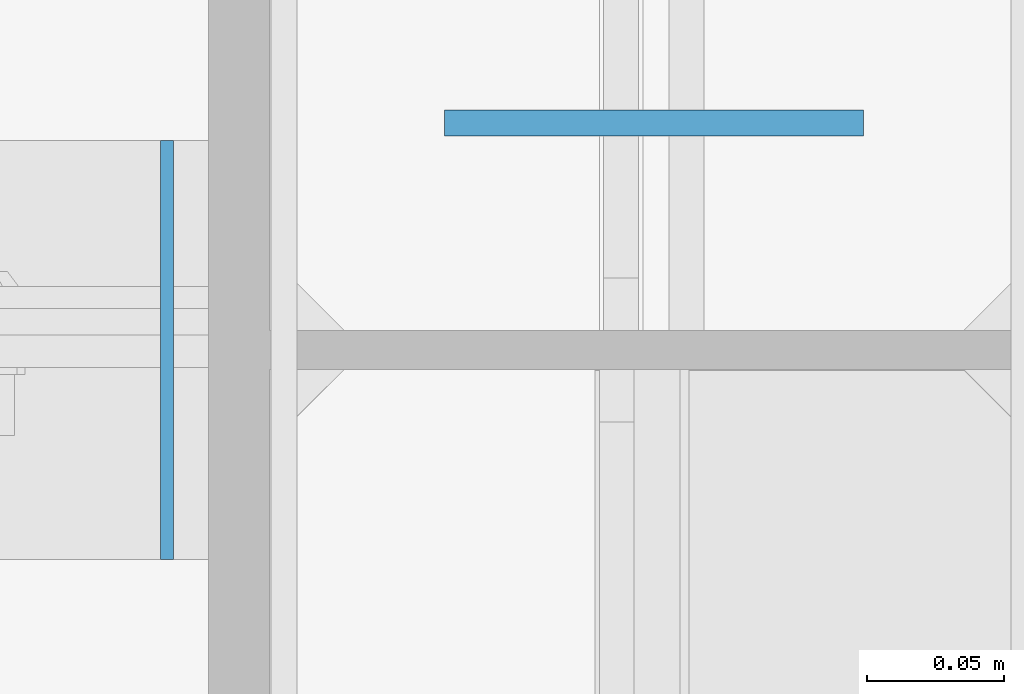
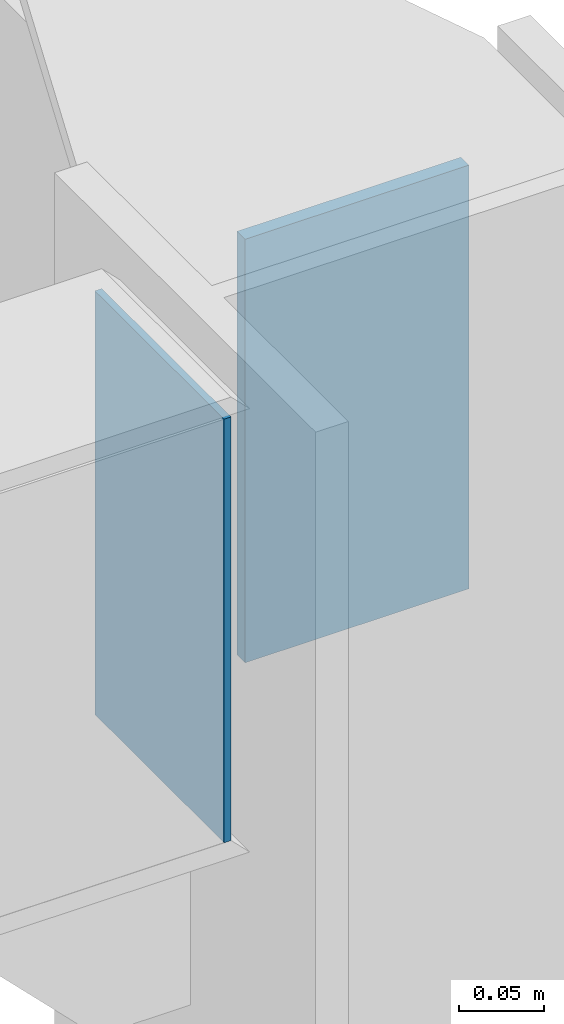
# One storey, part 556 of 1179: 2 columns, 2 elements without a shape of their own.
"""IFC2X3 building model written with IfcOpenShell, lengths in millimetres."""

from ifc_helpers import new_model, si_unit, frame, origin_with_axes, place, context, subcontext, project, spatial, faceted_brep, material, type_object, element, aggregate, save


model = new_model("IFC2X3")

# Units and contexts
model_context = context("Model", 3, precision=1e-05, world=origin_with_axes())
body_context = subcontext(model_context, "Body", "Model", "MODEL_VIEW")
ifc_project = project(units=[si_unit("LENGTHUNIT", "METRE", prefix="MILLI"), si_unit("AREAUNIT", "SQUARE_METRE"), si_unit("VOLUMEUNIT", "CUBIC_METRE"), si_unit("MASSUNIT", "GRAM", prefix="KILO"), si_unit("TIMEUNIT", "SECOND"), si_unit("PLANEANGLEUNIT", "RADIAN"), si_unit("SOLIDANGLEUNIT", "STERADIAN"), si_unit("THERMODYNAMICTEMPERATUREUNIT", "DEGREE_CELSIUS"), si_unit("LUMINOUSINTENSITYUNIT", "LUMEN")], contexts=[model_context])

# Site, building, storey
site_placement = place(None, origin_with_axes())
site = spatial("IfcSite", under=ifc_project, at=site_placement, CompositionType="ELEMENT")
building_placement = place(site_placement, origin_with_axes())
building = spatial("IfcBuilding", under=site, at=building_placement, Name="Undefined", CompositionType="ELEMENT")
storey_placement = place(building_placement, origin_with_axes())
storey = spatial("IfcBuildingStorey", under=building, at=storey_placement, Name="Undefined", CompositionType="ELEMENT", Elevation=0.0)

# Assembly, column
assembly_1_placement = place(storey_placement, origin_with_axes())
assembly_1 = element("IfcElementAssembly", 1, at=assembly_1_placement, inside=storey, Name="BEAM", AssemblyPlace="NOTDEFINED", PredefinedType="RIGID_FRAME")
ifc_material = material(Name="STEEL/A36")
column_type_1 = type_object("IfcColumnType", PredefinedType="NOTDEFINED")
column_1_placement = place(assembly_1_placement, frame((24307.8, 34474.15, 16122.65), z_axis=(1.0, 0.0, 0.0), x_axis=(0.0, 0.0, 1.0)))
column_1 = element("IfcColumn", 2, at=column_1_placement, type_object=column_type_1, material=ifc_material, Name="PLATE", context=body_context, shape_type="Brep", body=[
    faceted_brep([(0.0, 4.76249999999982, -76.1999999999971), (0.0, 4.76249999999982, 76.1999999999971), (304.799999999999, 4.76250000000073, 76.1999999999971), (304.799999999999, 4.76250000000073, -76.1999999999971), (0.0, -4.76249999999982, 76.1999999999971), (304.799999999999, -4.76250000000073, 76.1999999999971), (0.0, -4.76249999999982, -76.1999999999971), (304.799999999999, -4.76250000000073, -76.1999999999971)], [[[0, 1, 2, 3]], [[1, 4, 5, 2]], [[4, 6, 7, 5]], [[6, 0, 3, 7]], [[5, 7, 3, 2]], [[6, 4, 1, 0]]]),
])
aggregate(assembly_1, [column_1])

assembly_2_placement = place(storey_placement, origin_with_axes())
assembly_2 = element("IfcElementAssembly", 3, at=assembly_2_placement, inside=storey, Name="BEAM", AssemblyPlace="NOTDEFINED", PredefinedType="RIGID_FRAME")
column_type_2 = type_object("IfcColumnType", PredefinedType="NOTDEFINED")
column_2_placement = place(assembly_2_placement, frame((24130.7940000572, 34391.6, 16122.65), z_axis=(0.0, 1.0, 0.0), x_axis=(0.0, 0.0, 1.0)))
column_2 = element("IfcColumn", 4, at=column_2_placement, type_object=column_type_2, material=ifc_material, Name="PLATE", context=body_context, shape_type="Brep", body=[
    faceted_brep([(0.0, 2.38150000000041, -76.1999999999998), (0.0, 2.38150000000041, 76.1999999999998), (304.799999999999, 2.38150000000314, 76.2), (304.799999999999, 2.38150000000314, -76.2), (0.0, -2.38150000000041, 76.1999999999998), (304.799999999999, -2.38150000000314, 76.2), (0.0, -2.38150000000041, -76.1999999999998), (304.799999999999, -2.38150000000314, -76.2)], [[[0, 1, 2, 3]], [[1, 4, 5, 2]], [[4, 6, 7, 5]], [[6, 0, 3, 7]], [[5, 7, 3, 2]], [[6, 4, 1, 0]]]),
])
aggregate(assembly_2, [column_2])

save(model, "model.ifc")
